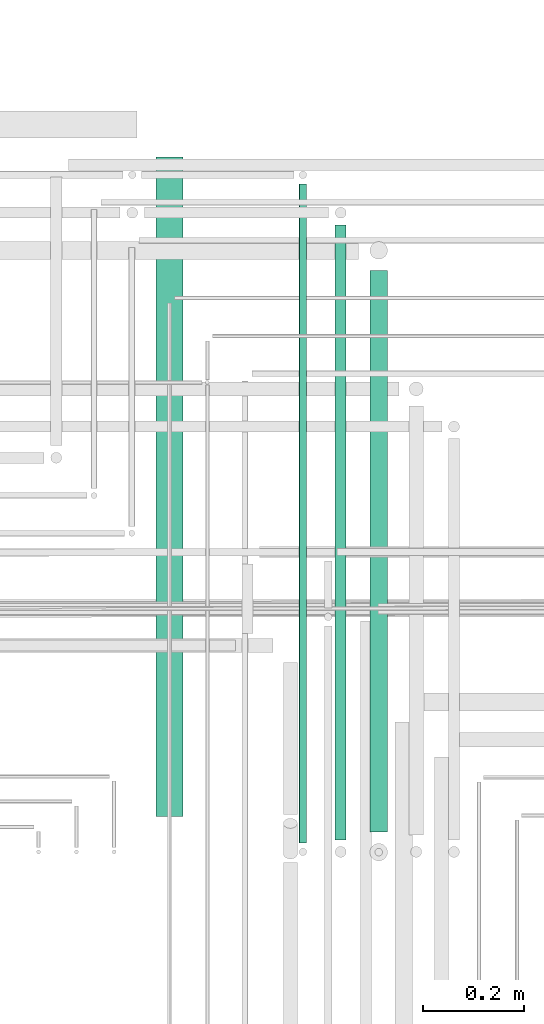
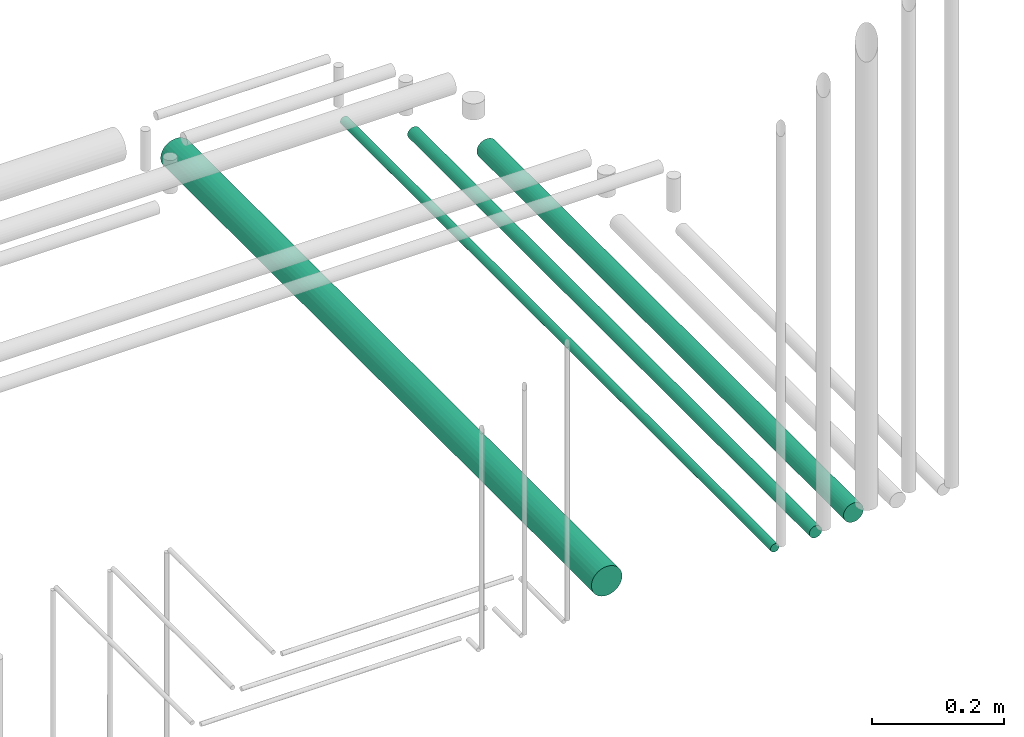
# One storey, part 87 of 331: 4 flow segments.
"""IFC2X3 building model written with IfcOpenShell, lengths in millimetres."""

from ifc_helpers import new_model, entity, si_unit, converted_unit, derived_unit, direction, frame, frame_2d, origin, origin_2d_with_axis, place, context, subcontext, project, spatial, circle, extrude, type_object, element, save


model = new_model("IFC2X3")

# Units and contexts
model_context = context("Model", 3, precision=0.01, world=origin(), true_north=direction((6.12303176911189e-17, 1.0)))
body_context = subcontext(model_context, "Body", "Model", "MODEL_VIEW")
ifc_project = project(units=[si_unit("LENGTHUNIT", "METRE", prefix="MILLI"), si_unit("AREAUNIT", "SQUARE_METRE"), si_unit("VOLUMEUNIT", "CUBIC_METRE"), converted_unit("PLANEANGLEUNIT", "DEGREE", entity("IfcRatioMeasure", 0.0174532925199433), si_unit("PLANEANGLEUNIT", "RADIAN"), dimensions=[0, 0, 0, 0, 0, 0, 0]), si_unit("MASSUNIT", "GRAM", prefix="KILO"), derived_unit("MASSDENSITYUNIT", [(si_unit("MASSUNIT", "GRAM", prefix="KILO"), 1), (si_unit("LENGTHUNIT", "METRE"), -3)]), derived_unit("MOMENTOFINERTIAUNIT", [(si_unit("LENGTHUNIT", "METRE"), 4)]), si_unit("TIMEUNIT", "SECOND"), si_unit("FREQUENCYUNIT", "HERTZ"), si_unit("THERMODYNAMICTEMPERATUREUNIT", "DEGREE_CELSIUS"), derived_unit("THERMALTRANSMITTANCEUNIT", [(si_unit("MASSUNIT", "GRAM", prefix="KILO"), 1), (si_unit("THERMODYNAMICTEMPERATUREUNIT", "KELVIN"), -1), (si_unit("TIMEUNIT", "SECOND"), -3)]), derived_unit("VOLUMETRICFLOWRATEUNIT", [(si_unit("LENGTHUNIT", "METRE"), 3), (si_unit("TIMEUNIT", "SECOND"), -1)]), derived_unit("MASSFLOWRATEUNIT", [(si_unit("MASSUNIT", "GRAM", prefix="KILO"), 1), (si_unit("TIMEUNIT", "SECOND"), -1)]), derived_unit("ROTATIONALFREQUENCYUNIT", [(si_unit("TIMEUNIT", "SECOND"), -1)]), si_unit("ELECTRICCURRENTUNIT", "AMPERE"), si_unit("ELECTRICVOLTAGEUNIT", "VOLT"), si_unit("POWERUNIT", "WATT"), si_unit("FORCEUNIT", "NEWTON", prefix="KILO"), si_unit("ILLUMINANCEUNIT", "LUX"), si_unit("LUMINOUSFLUXUNIT", "LUMEN"), si_unit("LUMINOUSINTENSITYUNIT", "CANDELA"), derived_unit("USERDEFINED", [(si_unit("MASSUNIT", "GRAM", prefix="KILO"), -1), (si_unit("LENGTHUNIT", "METRE"), -2), (si_unit("TIMEUNIT", "SECOND"), 3), (si_unit("LUMINOUSFLUXUNIT", "LUMEN"), 1)]), derived_unit("LINEARVELOCITYUNIT", [(si_unit("LENGTHUNIT", "METRE"), 1), (si_unit("TIMEUNIT", "SECOND"), -1)]), si_unit("PRESSUREUNIT", "PASCAL"), derived_unit("USERDEFINED", [(si_unit("LENGTHUNIT", "METRE"), -2), (si_unit("MASSUNIT", "GRAM", prefix="KILO"), 1), (si_unit("TIMEUNIT", "SECOND"), -2)]), derived_unit("LINEARFORCEUNIT", [(si_unit("MASSUNIT", "GRAM", prefix="KILO"), 1), (si_unit("LENGTHUNIT", "METRE"), 1), (si_unit("TIMEUNIT", "SECOND"), -2), (si_unit("LENGTHUNIT", "METRE"), -1)]), derived_unit("PLANARFORCEUNIT", [(si_unit("MASSUNIT", "GRAM", prefix="KILO"), 1), (si_unit("LENGTHUNIT", "METRE"), 1), (si_unit("TIMEUNIT", "SECOND"), -2), (si_unit("LENGTHUNIT", "METRE"), -2)])], contexts=[model_context])

# Site, building, storey
site_placement = place(None, frame((0.0, -0.00077364408347762, 0.0)))
site = spatial("IfcSite", under=ifc_project, at=site_placement, CompositionType="ELEMENT")
building_placement = place(site_placement, origin())
building = spatial("IfcBuilding", under=site, at=building_placement, CompositionType="ELEMENT")
storey_placement = place(building_placement, origin())
storey = spatial("IfcBuildingStorey", under=building, at=storey_placement, CompositionType="ELEMENT", Elevation=0.0)

# Flow segments
pipe_segment_type = type_object("IfcPipeSegmentType", PredefinedType="NOTDEFINED")
flow_segment_1_placement = place(storey_placement, frame((65056.5166110417, 7735.14924977555, 18421.4047277641)))
element("IfcFlowSegment", 1, at=flow_segment_1_placement, inside=storey, type_object=pipe_segment_type, context=body_context, shape_type="SweptSolid", body=[
    extrude(circle(Radius=27.0, at=origin_2d_with_axis()), frame((28.5952722359184, 0.0, 28.5952722359163), z_axis=(0.0, 1.0, 0.0), x_axis=(-1.0, 0.0, 0.0)), (0.0, 0.0, 1.0), 1309.99917341641),
])
flow_segment_2_placement = place(storey_placement, frame((65341.0166110417, 7683.14924977607, 18440.9047277641)))
element("IfcFlowSegment", 2, at=flow_segment_2_placement, inside=storey, type_object=pipe_segment_type, context=body_context, shape_type="SweptSolid", body=[
    extrude(circle(Radius=7.5, at=frame_2d((-8.66293703438714e-12, 0.0), x_axis=(1.0, 0.0))), frame((9.09527223591419, 0.0, 9.09527223591636), z_axis=(0.0, 1.0, 0.0), x_axis=(-1.0, 0.0, 0.0)), (0.0, 0.0, 1.0), 1308.66148470613),
])
flow_segment_3_placement = place(storey_placement, frame((65412.5166110417, 7689.14924977607, 18437.4047277641)))
element("IfcFlowSegment", 3, at=flow_segment_3_placement, inside=storey, type_object=pipe_segment_type, context=body_context, shape_type="SweptSolid", body=[
    extrude(circle(Radius=11.0, at=origin_2d_with_axis()), frame((12.5952722359134, 0.0, 12.5952722359156), z_axis=(0.0, 1.0, 0.0), x_axis=(-1.0, 0.0, 0.0)), (0.0, 0.0, 1.0), 1221.66148470612),
])
flow_segment_4_placement = place(storey_placement, frame((65481.517459311, 7704.64840150688, 18430.9047277641)))
element("IfcFlowSegment", 4, at=flow_segment_4_placement, inside=storey, type_object=pipe_segment_type, context=body_context, shape_type="SweptSolid", body=[
    extrude(circle(Radius=17.5, at=origin_2d_with_axis()), frame((19.0952722359119, 0.0, 19.0952722359163), z_axis=(0.0, 1.0, 0.0), x_axis=(-1.0, 0.0, 0.0)), (0.0, 0.0, 1.0), 1115.16233297526),
])

save(model, "model.ifc")
